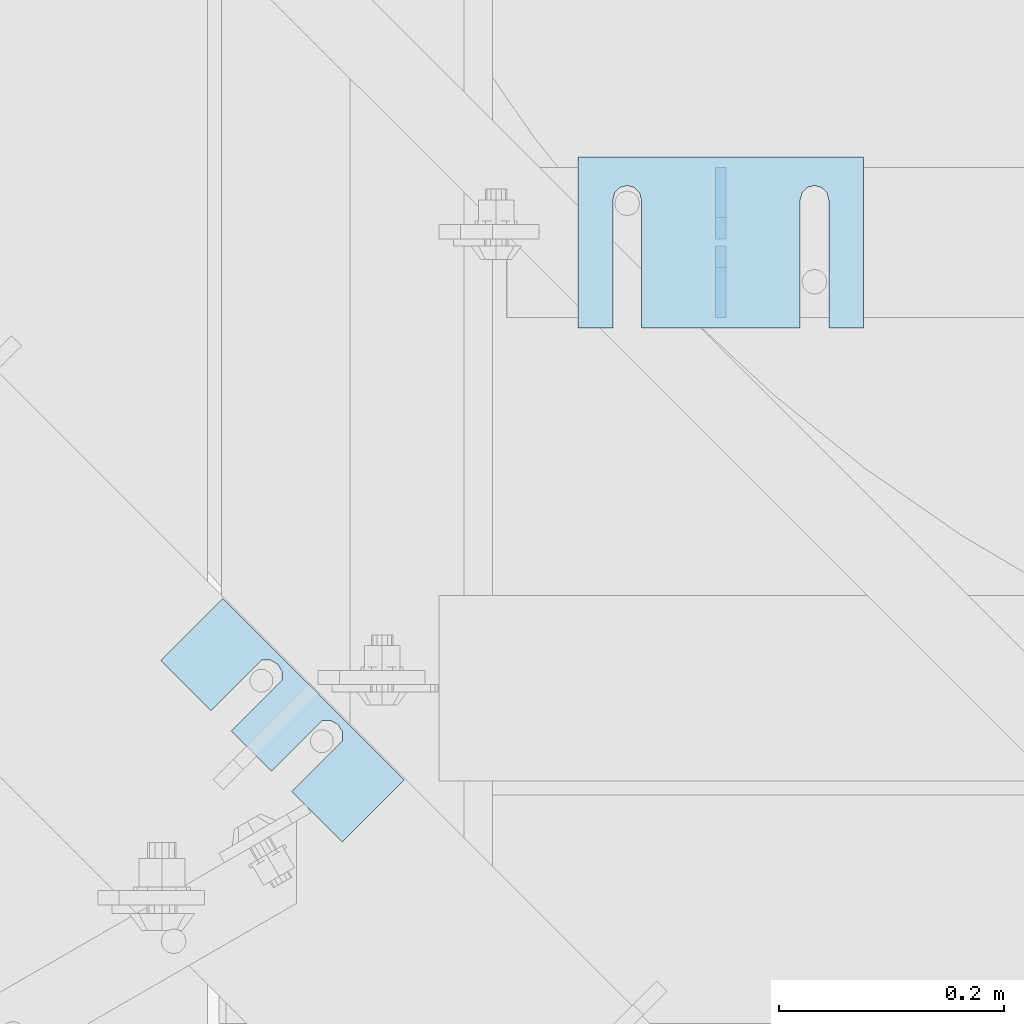
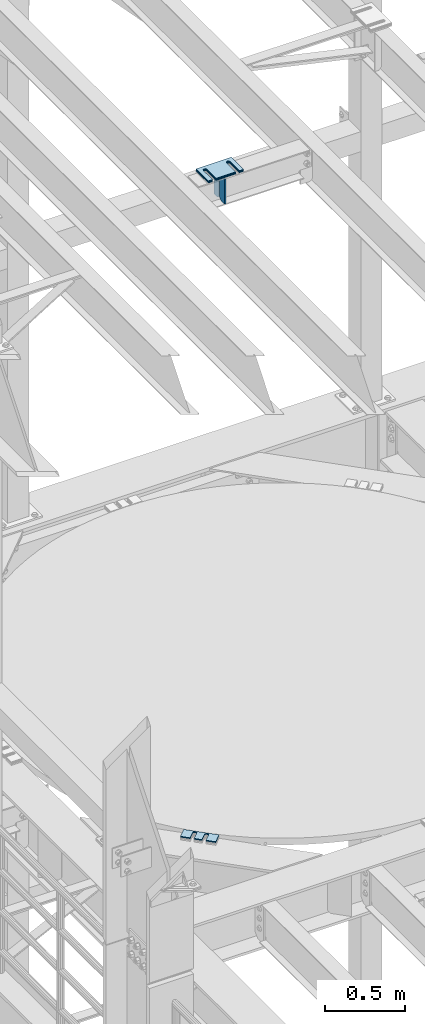
# One storey, part 1761 of 1876: 10 plates, 9 elements without a shape of their own.
"""IFC2X3 building model written with IfcOpenShell, lengths in millimetres."""

from ifc_helpers import new_model, si_unit, frame, origin_with_axes, place, context, subcontext, project, spatial, faceted_brep, material, type_object, element, aggregate, save


model = new_model("IFC2X3")

# Units and contexts
model_context = context("Model", 3, precision=1e-05, world=origin_with_axes())
body_context = subcontext(model_context, "Body", "Model", "MODEL_VIEW")
ifc_project = project(units=[si_unit("LENGTHUNIT", "METRE", prefix="MILLI"), si_unit("AREAUNIT", "SQUARE_METRE"), si_unit("VOLUMEUNIT", "CUBIC_METRE"), si_unit("MASSUNIT", "GRAM", prefix="KILO"), si_unit("TIMEUNIT", "SECOND"), si_unit("PLANEANGLEUNIT", "RADIAN"), si_unit("SOLIDANGLEUNIT", "STERADIAN"), si_unit("THERMODYNAMICTEMPERATUREUNIT", "DEGREE_CELSIUS"), si_unit("LUMINOUSINTENSITYUNIT", "LUMEN")], contexts=[model_context])

# Site, building, storey
site_placement = place(None, origin_with_axes())
site = spatial("IfcSite", under=ifc_project, at=site_placement, CompositionType="ELEMENT")
building_placement = place(site_placement, origin_with_axes())
building = spatial("IfcBuilding", under=site, at=building_placement, Name="Undefined", CompositionType="ELEMENT")
storey_placement = place(building_placement, origin_with_axes())
storey = spatial("IfcBuildingStorey", under=building, at=storey_placement, Name="Undefined", CompositionType="ELEMENT", Elevation=0.0)

# Assembly, plates
assembly_1_placement = place(storey_placement, origin_with_axes())
assembly_1 = element("IfcElementAssembly", 1, at=assembly_1_placement, inside=storey, Name="BEAM", AssemblyPlace="NOTDEFINED", PredefinedType="RIGID_FRAME")
ifc_material = material(Name="STEEL/A36")
plate_type_1 = type_object("IfcPlateType", PredefinedType="NOTDEFINED")
plate_1_placement = place(assembly_1_placement, frame((2184.41047110072, 10445.7476196289, 17784.7625), z_axis=(0.0, 0.0, 1.0), x_axis=(0.0, 1.0, 0.0)))
plate_1 = element("IfcPlate", 2, at=plate_1_placement, type_object=plate_type_1, material=ifc_material, Name="PLATE", context=body_context, shape_type="Brep", body=[
    faceted_brep([(0.0, -4.76249999999982, 0.0), (0.0, -4.76249999999982, 190.5), (0.0, 4.76249999999982, 190.5), (0.0, 4.76249999999982, 0.0), (44.4500007629395, -4.76249999999982, 190.5), (44.4500007629395, 4.76249999999982, 190.5), (63.5, -4.76249999999982, 171.450000762939), (63.5, 4.76249999999982, 171.450000762939), (63.5, -4.76249999999982, 19.0499992370605), (63.5, 4.76249999999982, 19.0499992370605), (44.4500007629395, -4.76249999999982, 0.0), (44.4500007629395, 4.76249999999982, 0.0)], [[[0, 1, 2, 3]], [[1, 4, 5, 2]], [[4, 6, 7, 5]], [[6, 8, 9, 7]], [[8, 10, 11, 9]], [[10, 0, 3, 11]], [[5, 7, 9, 11, 3, 2]], [[10, 8, 6, 4, 1, 0]]]),
])
plate_2_placement = place(assembly_1_placement, frame((2184.41047110072, 10515.5976196289, 17784.7625), z_axis=(0.0, 0.0, 1.0), x_axis=(0.0, 1.0, 0.0)))
plate_2 = element("IfcPlate", 3, at=plate_2_placement, type_object=plate_type_1, material=ifc_material, Name="PLATE", context=body_context, shape_type="Brep", body=[
    faceted_brep([(0.0, -4.76249999999982, 19.0499992370605), (0.0, -4.76249999999982, 171.450000762939), (0.0, 4.76249999999982, 171.450000762939), (0.0, 4.76249999999982, 19.0499992370605), (19.0499992370605, -4.76249999999982, 190.5), (19.0499992370605, 4.76249999999982, 190.5), (63.5, -4.76249999999982, 190.5), (63.5, 4.76249999999982, 190.5), (63.5, -4.76249999999982, 0.0), (63.5, 4.76249999999982, 0.0), (19.0499992370605, -4.76249999999982, 0.0), (19.0499992370605, 4.76249999999982, 0.0)], [[[0, 1, 2, 3]], [[1, 4, 5, 2]], [[4, 6, 7, 5]], [[6, 8, 9, 7]], [[8, 10, 11, 9]], [[10, 0, 3, 11]], [[5, 7, 9, 11, 3, 2]], [[10, 8, 6, 4, 1, 0]]]),
])
aggregate(assembly_1, [plate_1, plate_2])

# Assembly, plate
assembly_2_placement = place(storey_placement, origin_with_axes())
assembly_2 = element("IfcElementAssembly", 4, at=assembly_2_placement, inside=storey, Name="SHIM PLATE", AssemblyPlace="NOTDEFINED", PredefinedType="RIGID_FRAME")
plate_type_2 = type_object("IfcPlateType", PredefinedType="NOTDEFINED")
plate_3_placement = place(assembly_2_placement, frame((1685.49921187468, 10140.2424941069, 13335.7925), z_axis=(0.707124703959405, -0.707088857959397, 0.0), x_axis=(0.707088857959397, 0.707124703959405, 0.0)))
plate_3 = element("IfcPlate", 5, at=plate_3_placement, type_object=plate_type_2, material=ifc_material, Name="SHIM PLATE", context=body_context, shape_type="Brep", body=[
    faceted_brep([(-2.69435986410826e-07, -0.793499999999767, 88.9036802523933), (-2.69435986410826e-07, 0.793499999999767, 88.9036802523933), (64.2890073715625, 0.793499999999767, 88.9052190745724), (64.2890073715625, -0.793499999999767, 88.9052190745724), (69.5243873298787, 0.793499999999767, 83.4915584105911), (69.5243873298787, -0.793499999999767, 83.4915584105911), (64.2896161919252, -0.793499999999767, 63.5071916498637), (64.2896161919252, 0.793499999999767, 63.5071916498637), (-1.92456354852766e-07, 0.793499999999767, 63.5036806291719), (-1.92456354852766e-07, -0.793499999999767, 63.5036806291719), (69.5247366006915, -0.793499999999767, 68.9211033039346), (69.5247366006915, 0.793499999999767, 68.9211033039346), (71.4330651893342, -0.793499999999767, 76.2063766063075), (71.4330651893342, 0.793499999999767, 76.2063766063075), (64.2877911166179, -0.793499999999767, 139.707191628078), (64.2877911166179, 0.793499999999767, 139.707191628078), (-4.23393430537544e-07, 0.793499999999767, 139.703680607393), (-4.23393430537544e-07, -0.793499999999767, 139.703680607393), (69.522911525386, -0.793499999999767, 145.12110328215), (69.522911525386, 0.793499999999767, 145.12110328215), (71.4312401140269, -0.793499999999767, 152.406376584524), (71.4312401140269, 0.793499999999767, 152.406376584524), (69.5225622545713, -0.793499999999767, 159.691558388807), (69.5225622545713, 0.793499999999767, 159.691558388807), (64.287182296257, -0.793499999999767, 165.105219052788), (64.287182296257, 0.793499999999767, 165.105219052788), (-5.00373062095605e-07, -0.793499999999767, 165.103680230615), (-5.00373062095605e-07, 0.793499999999767, 165.103680230615), (-6.92811227054335e-07, -0.793499999999767, 228.601303100698), (-6.92811227054335e-07, 0.793499999999767, 228.601303100698), (78.1460113524699, -0.793499999999767, 228.601303100651), (78.1460113524699, 0.793499999999767, 228.601303100651), (78.1460113525918, -0.793499999999767, -4.91127138957381e-11), (78.1460113525918, 0.793499999999767, -4.91127138957381e-11), (9.09494701772928e-13, -0.793499999999767, 0.0), (9.09494701772928e-13, 0.793499999999767, 0.0)], [[[0, 1, 2, 3]], [[3, 2, 4, 5]], [[6, 7, 8, 9]], [[10, 11, 7, 6]], [[12, 13, 11, 10]], [[5, 4, 13, 12]], [[14, 15, 16, 17]], [[18, 19, 15, 14]], [[20, 21, 19, 18]], [[22, 23, 21, 20]], [[24, 25, 23, 22]], [[26, 27, 25, 24]], [[28, 29, 27, 26]], [[28, 30, 31, 29]], [[30, 32, 33, 31]], [[32, 34, 35, 33]], [[35, 34, 9, 8]], [[2, 1, 16, 15, 19, 21, 23, 25, 27, 29, 31, 33, 35, 8, 7, 11, 13, 4]], [[17, 16, 1, 0]], [[6, 9, 34, 32, 30, 28, 26, 24, 22, 20, 18, 14, 17, 0, 3, 5, 12, 10]]]),
])
aggregate(assembly_2, [plate_3])

assembly_3_placement = place(storey_placement, origin_with_axes())
assembly_3 = element("IfcElementAssembly", 6, at=assembly_3_placement, inside=storey, Name="SHIM PLATE", AssemblyPlace="NOTDEFINED", PredefinedType="RIGID_FRAME")
plate_type_3 = type_object("IfcPlateType", PredefinedType="NOTDEFINED")
plate_4_placement = place(assembly_3_placement, frame((1685.49921187468, 10140.2424941069, 13333.4115), z_axis=(0.707124703959405, -0.707088857959397, 0.0), x_axis=(0.707088857959397, 0.707124703959405, 0.0)))
plate_4 = element("IfcPlate", 7, at=plate_4_placement, type_object=plate_type_3, material=ifc_material, Name="SHIM PLATE", context=body_context, shape_type="Brep", body=[
    faceted_brep([(-2.69435986410826e-07, -1.58749999999964, 88.9036802523951), (-2.69435986410826e-07, 1.58749999999964, 88.9036802523951), (64.2890073715644, 1.58749999999964, 88.9052190745733), (64.2890073715644, -1.58749999999964, 88.9052190745733), (69.5243873298787, 1.58749999999964, 83.491558410592), (69.5243873298787, -1.58749999999964, 83.491558410592), (64.2896161919234, -1.58749999999964, 63.5071916498646), (64.2896161919234, 1.58749999999964, 63.5071916498646), (-1.92456354852766e-07, 1.58749999999964, 63.5036806291737), (-1.92456354852766e-07, -1.58749999999964, 63.5036806291737), (69.5247366006934, -1.58749999999964, 68.9211033039355), (69.5247366006934, 1.58749999999964, 68.9211033039355), (71.4330651893342, -1.58749999999964, 76.2063766063084), (71.4330651893342, 1.58749999999964, 76.2063766063084), (64.2877911166179, -1.58749999999964, 139.707191628079), (64.2877911166179, 1.58749999999964, 139.707191628079), (-4.23391611548141e-07, 1.58749999999964, 139.703680607395), (-4.23391611548141e-07, -1.58749999999964, 139.703680607395), (69.522911525386, -1.58749999999964, 145.121103282152), (69.522911525386, 1.58749999999964, 145.121103282152), (71.4312401140269, -1.58749999999964, 152.406376584525), (71.4312401140269, 1.58749999999964, 152.406376584525), (69.5225622545713, -1.58749999999964, 159.691558388808), (69.5225622545713, 1.58749999999964, 159.691558388808), (64.2871822962588, -1.58749999999964, 165.105219052789), (64.2871822962588, 1.58749999999964, 165.105219052789), (-5.00371243106201e-07, -1.58749999999964, 165.103680230615), (-5.00371243106201e-07, 1.58749999999964, 165.103680230615), (-6.92813046043739e-07, -1.58749999999964, 228.601303100699), (-6.92813046043739e-07, 1.58749999999964, 228.601303100699), (78.1460113524699, -1.58749999999964, 228.601303100651), (78.1460113524699, 1.58749999999964, 228.601303100651), (78.1460113525918, -1.58749999999964, -4.72937244921923e-11), (78.1460113525918, 1.58749999999964, -4.72937244921923e-11), (9.09494701772928e-13, -1.58750000000146, 4.54747350886464e-13), (9.09494701772928e-13, 1.58750000000146, 4.54747350886464e-13)], [[[0, 1, 2, 3]], [[3, 2, 4, 5]], [[6, 7, 8, 9]], [[10, 11, 7, 6]], [[12, 13, 11, 10]], [[5, 4, 13, 12]], [[14, 15, 16, 17]], [[18, 19, 15, 14]], [[20, 21, 19, 18]], [[22, 23, 21, 20]], [[24, 25, 23, 22]], [[26, 27, 25, 24]], [[28, 29, 27, 26]], [[28, 30, 31, 29]], [[30, 32, 33, 31]], [[32, 34, 35, 33]], [[35, 34, 9, 8]], [[2, 1, 16, 15, 19, 21, 23, 25, 27, 29, 31, 33, 35, 8, 7, 11, 13, 4]], [[17, 16, 1, 0]], [[6, 9, 34, 32, 30, 28, 26, 24, 22, 20, 18, 14, 17, 0, 3, 5, 12, 10]]]),
])
aggregate(assembly_3, [plate_4])

assembly_4_placement = place(storey_placement, origin_with_axes())
assembly_4 = element("IfcElementAssembly", 8, at=assembly_4_placement, inside=storey, Name="SHIM PLATE", AssemblyPlace="NOTDEFINED", PredefinedType="RIGID_FRAME")
plate_5_placement = place(assembly_4_placement, frame((1685.49921187468, 10140.2424941069, 13330.2365), z_axis=(0.707124703959405, -0.707088857959397, 0.0), x_axis=(0.707088857959397, 0.707124703959405, 0.0)))
plate_5 = element("IfcPlate", 9, at=plate_5_placement, type_object=plate_type_3, material=ifc_material, Name="SHIM PLATE", context=body_context, shape_type="Brep", body=[
    faceted_brep([(-2.69435986410826e-07, -1.58749999999964, 88.9036802523951), (-2.69435986410826e-07, 1.58749999999964, 88.9036802523951), (64.2890073715644, 1.58749999999964, 88.9052190745733), (64.2890073715644, -1.58749999999964, 88.9052190745733), (69.5243873298787, 1.58749999999964, 83.491558410592), (69.5243873298787, -1.58749999999964, 83.491558410592), (64.2896161919234, -1.58749999999964, 63.5071916498646), (64.2896161919234, 1.58749999999964, 63.5071916498646), (-1.92456354852766e-07, 1.58749999999964, 63.5036806291737), (-1.92456354852766e-07, -1.58749999999964, 63.5036806291737), (69.5247366006934, -1.58749999999964, 68.9211033039355), (69.5247366006934, 1.58749999999964, 68.9211033039355), (71.4330651893342, -1.58749999999964, 76.2063766063084), (71.4330651893342, 1.58749999999964, 76.2063766063084), (64.2877911166179, -1.58749999999964, 139.707191628079), (64.2877911166179, 1.58749999999964, 139.707191628079), (-4.23391611548141e-07, 1.58749999999964, 139.703680607395), (-4.23391611548141e-07, -1.58749999999964, 139.703680607395), (69.522911525386, -1.58749999999964, 145.121103282152), (69.522911525386, 1.58749999999964, 145.121103282152), (71.4312401140269, -1.58749999999964, 152.406376584525), (71.4312401140269, 1.58749999999964, 152.406376584525), (69.5225622545713, -1.58749999999964, 159.691558388808), (69.5225622545713, 1.58749999999964, 159.691558388808), (64.2871822962588, -1.58749999999964, 165.105219052789), (64.2871822962588, 1.58749999999964, 165.105219052789), (-5.00371243106201e-07, -1.58749999999964, 165.103680230615), (-5.00371243106201e-07, 1.58749999999964, 165.103680230615), (-6.92813046043739e-07, -1.58749999999964, 228.601303100699), (-6.92813046043739e-07, 1.58749999999964, 228.601303100699), (78.1460113524699, -1.58749999999964, 228.601303100651), (78.1460113524699, 1.58749999999964, 228.601303100651), (78.1460113525918, -1.58749999999964, -4.72937244921923e-11), (78.1460113525918, 1.58749999999964, -4.72937244921923e-11), (9.09494701772928e-13, -1.58750000000146, 4.54747350886464e-13), (9.09494701772928e-13, 1.58750000000146, 4.54747350886464e-13)], [[[0, 1, 2, 3]], [[3, 2, 4, 5]], [[6, 7, 8, 9]], [[10, 11, 7, 6]], [[12, 13, 11, 10]], [[5, 4, 13, 12]], [[14, 15, 16, 17]], [[18, 19, 15, 14]], [[20, 21, 19, 18]], [[22, 23, 21, 20]], [[24, 25, 23, 22]], [[26, 27, 25, 24]], [[28, 29, 27, 26]], [[28, 30, 31, 29]], [[30, 32, 33, 31]], [[32, 34, 35, 33]], [[35, 34, 9, 8]], [[2, 1, 16, 15, 19, 21, 23, 25, 27, 29, 31, 33, 35, 8, 7, 11, 13, 4]], [[17, 16, 1, 0]], [[6, 9, 34, 32, 30, 28, 26, 24, 22, 20, 18, 14, 17, 0, 3, 5, 12, 10]]]),
])
aggregate(assembly_4, [plate_5])

assembly_5_placement = place(storey_placement, origin_with_axes())
assembly_5 = element("IfcElementAssembly", 10, at=assembly_5_placement, inside=storey, Name="SHIM PLATE", AssemblyPlace="NOTDEFINED", PredefinedType="RIGID_FRAME")
plate_type_4 = type_object("IfcPlateType", PredefinedType="NOTDEFINED")
plate_6_placement = place(assembly_5_placement, frame((2311.41072536354, 10588.6220636382, 18009.3925), z_axis=(0.0, -1.0, 0.0), x_axis=(-1.0, 0.0, 0.0)))
plate_6 = element("IfcPlate", 11, at=plate_6_placement, type_object=plate_type_4, material=ifc_material, Name="SHIM PLATE", context=body_context, shape_type="Brep", body=[
    faceted_brep([(30.8791924037423, -0.793499999999767, 152.398895263674), (30.8814140421409, -0.793499999999767, 38.0994505407325), (30.8814140421409, 0.793499999999767, 38.0994505407325), (30.8791924037423, 0.793499999999767, 152.398895263674), (32.5828868936751, -0.793499999999767, 31.7494480341243), (32.5828868936751, 0.793499999999767, 31.7494480341243), (37.2314075583954, -0.793499999999767, 27.1009216732054), (37.2314075583954, 0.793499999999767, 27.1009216732054), (43.5814079800521, -0.793499999999767, 25.3994410405157), (43.5814079800521, 0.793499999999767, 25.3994410405157), (49.9314097200559, -0.793499999999767, 27.1009167530574), (49.9314097200559, 0.793499999999767, 27.1009167530574), (54.5799339865616, -0.793499999999767, 31.7494395121785), (54.5799339865616, 0.793499999999767, 31.7494395121785), (56.2814117582284, -0.793499999999767, 38.0994407004391), (56.2814117582284, 0.793499999999767, 38.0994407004391), (56.2791901197206, -0.793499999999767, 152.398894414155), (56.2791901197206, 0.793499999999767, 152.398895263676), (9.09494701772928e-13, -0.793499999999767, 0.0), (1.98268335225293e-05, -0.793499999999767, 152.398895263672), (1.98268335225293e-05, 0.793499999999767, 152.398895263672), (9.09494701772928e-13, 0.793499999999767, 0.0), (253.999542236328, -0.793499999999767, 6.16182660451159e-11), (253.999542236328, 0.793499999999767, 6.16182660451159e-11), (253.999557495107, -0.793499999999767, 152.398895263688), (253.999557495107, 0.793499999999767, 152.398895263688), (223.116882380463, 0.793499999999767, 152.398895263686), (223.116882380463, -0.793499999999767, 152.398895415181), (223.119104018971, 0.793499999999767, 38.0994417014649), (223.119104018971, -0.793499999999767, 38.0994417014649), (221.417626247304, 0.793499999999767, 31.7494405132047), (221.417626247304, -0.793499999999767, 31.7494405132047), (216.769101980798, 0.793499999999767, 27.1009177540836), (216.769101980798, -0.793499999999767, 27.1009177540836), (210.419100240794, 0.793499999999767, 25.399442041542), (210.419100240794, -0.793499999999767, 25.399442041542), (204.069099819138, 0.793499999999767, 27.1009226742317), (204.069099819138, -0.793499999999767, 27.1009226742317), (199.420579154417, 0.793499999999767, 31.7494490351505), (199.420579154417, -0.793499999999767, 31.7494490351505), (197.719106302883, 0.793499999999767, 38.0994515417583), (197.719106302883, -0.793499999999767, 38.0994515417583), (197.716884664484, -0.793499999999767, 152.398895263684), (197.716884664484, 0.793499999999767, 152.398895263684)], [[[0, 1, 2, 3]], [[4, 5, 2, 1]], [[6, 7, 5, 4]], [[8, 9, 7, 6]], [[10, 11, 9, 8]], [[12, 13, 11, 10]], [[14, 15, 13, 12]], [[16, 17, 15, 14]], [[18, 19, 20, 21]], [[22, 18, 21, 23]], [[24, 22, 23, 25]], [[24, 25, 26, 27]], [[27, 26, 28, 29]], [[29, 28, 30, 31]], [[31, 30, 32, 33]], [[33, 32, 34, 35]], [[35, 34, 36, 37]], [[37, 36, 38, 39]], [[39, 38, 40, 41]], [[42, 41, 40, 43]], [[12, 10, 8, 6, 4, 1, 0, 19, 18, 22, 24, 27, 29, 31, 33, 35, 37, 39, 41, 42, 16, 14]], [[20, 19, 0, 3]], [[43, 40, 38, 36, 34, 32, 30, 28, 26, 25, 23, 21, 20, 3, 2, 5, 7, 9, 11, 13, 15, 17]], [[42, 43, 17, 16]]]),
])
aggregate(assembly_5, [plate_6])

assembly_6_placement = place(storey_placement, origin_with_axes())
assembly_6 = element("IfcElementAssembly", 12, at=assembly_6_placement, inside=storey, Name="SHIM PLATE", AssemblyPlace="NOTDEFINED", PredefinedType="RIGID_FRAME")
plate_type_5 = type_object("IfcPlateType", PredefinedType="NOTDEFINED")
plate_7_placement = place(assembly_6_placement, frame((2311.41072536354, 10588.6220636384, 18007.0115), z_axis=(0.0, -1.0, 0.0), x_axis=(-1.0, 0.0, 0.0)))
plate_7 = element("IfcPlate", 13, at=plate_7_placement, type_object=plate_type_5, material=ifc_material, Name="SHIM PLATE", context=body_context, shape_type="Brep", body=[
    faceted_brep([(30.8791924037423, -1.58750000000146, 152.398895263674), (30.8814140421409, -1.58750000000146, 38.0994505407325), (30.8814140421409, 1.58750000000146, 38.0994505407325), (30.8791924037423, 1.58750000000146, 152.398895263674), (32.5828868936751, -1.58750000000146, 31.7494480341243), (32.5828868936751, 1.58750000000146, 31.7494480341243), (37.2314075583954, -1.58750000000146, 27.1009216732054), (37.2314075583954, 1.58750000000146, 27.1009216732054), (43.5814079800521, -1.58750000000146, 25.3994410405157), (43.5814079800521, 1.58750000000146, 25.3994410405157), (49.9314097200559, -1.58750000000146, 27.1009167530574), (49.9314097200559, 1.58750000000146, 27.1009167530574), (54.5799339865616, -1.58750000000146, 31.7494395121785), (54.5799339865616, 1.58750000000146, 31.7494395121785), (56.2814117582284, -1.58750000000146, 38.0994407004391), (56.2814117582284, 1.58750000000146, 38.0994407004391), (56.2791901197206, -1.58750000000146, 152.398894414155), (56.2791901197206, 1.58750000000146, 152.398895263676), (9.09494701772928e-13, -1.58750000000146, 4.54747350886464e-13), (1.98264133359771e-05, -1.58750000000146, 152.398895263672), (1.98264133359771e-05, 1.58750000000146, 152.398895263672), (9.09494701772928e-13, 1.58750000000146, 4.54747350886464e-13), (253.999542236328, -1.58750000000146, 6.16182660451159e-11), (253.999542236328, 1.58750000000146, 6.16182660451159e-11), (253.999557495107, -1.58750000000146, 152.398895263688), (253.999557495107, 1.58750000000146, 152.398895263688), (223.116882380463, 1.58750000000146, 152.398895263686), (223.116882380463, -1.58750000000146, 152.398895415181), (223.119104018971, 1.58750000000146, 38.0994417014649), (223.119104018971, -1.58750000000146, 38.0994417014649), (221.417626247304, 1.58750000000146, 31.7494405132047), (221.417626247304, -1.58750000000146, 31.7494405132047), (216.769101980798, 1.58750000000146, 27.1009177540836), (216.769101980798, -1.58750000000146, 27.1009177540836), (210.419100240794, 1.58750000000146, 25.399442041542), (210.419100240794, -1.58750000000146, 25.399442041542), (204.069099819138, 1.58750000000146, 27.1009226742317), (204.069099819138, -1.58750000000146, 27.1009226742317), (199.420579154417, 1.58750000000146, 31.7494490351505), (199.420579154417, -1.58750000000146, 31.7494490351505), (197.719106302883, 1.58750000000146, 38.0994515417583), (197.719106302883, -1.58750000000146, 38.0994515417583), (197.716884664484, -1.58750000000146, 152.398895263684), (197.716884664484, 1.58750000000146, 152.398895263684)], [[[0, 1, 2, 3]], [[4, 5, 2, 1]], [[6, 7, 5, 4]], [[8, 9, 7, 6]], [[10, 11, 9, 8]], [[12, 13, 11, 10]], [[14, 15, 13, 12]], [[16, 17, 15, 14]], [[18, 19, 20, 21]], [[22, 18, 21, 23]], [[24, 22, 23, 25]], [[24, 25, 26, 27]], [[27, 26, 28, 29]], [[29, 28, 30, 31]], [[31, 30, 32, 33]], [[33, 32, 34, 35]], [[35, 34, 36, 37]], [[37, 36, 38, 39]], [[39, 38, 40, 41]], [[42, 41, 40, 43]], [[12, 10, 8, 6, 4, 1, 0, 19, 18, 22, 24, 27, 29, 31, 33, 35, 37, 39, 41, 42, 16, 14]], [[20, 19, 0, 3]], [[43, 40, 38, 36, 34, 32, 30, 28, 26, 25, 23, 21, 20, 3, 2, 5, 7, 9, 11, 13, 15, 17]], [[42, 43, 17, 16]]]),
])
aggregate(assembly_6, [plate_7])

assembly_7_placement = place(storey_placement, origin_with_axes())
assembly_7 = element("IfcElementAssembly", 14, at=assembly_7_placement, inside=storey, Name="SHIM PLATE", AssemblyPlace="NOTDEFINED", PredefinedType="RIGID_FRAME")
plate_8_placement = place(assembly_7_placement, frame((2311.41072536354, 10588.6220636387, 18003.8365), z_axis=(0.0, -1.0, 0.0), x_axis=(-1.0, 0.0, 0.0)))
plate_8 = element("IfcPlate", 15, at=plate_8_placement, type_object=plate_type_5, material=ifc_material, Name="SHIM PLATE", context=body_context, shape_type="Brep", body=[
    faceted_brep([(30.8791924037423, -1.58750000000146, 152.398895263674), (30.8814140421409, -1.58750000000146, 38.0994505407325), (30.8814140421409, 1.58750000000146, 38.0994505407325), (30.8791924037423, 1.58750000000146, 152.398895263674), (32.5828868936751, -1.58750000000146, 31.7494480341243), (32.5828868936751, 1.58750000000146, 31.7494480341243), (37.2314075583954, -1.58750000000146, 27.1009216732054), (37.2314075583954, 1.58750000000146, 27.1009216732054), (43.5814079800521, -1.58750000000146, 25.3994410405157), (43.5814079800521, 1.58750000000146, 25.3994410405157), (49.9314097200559, -1.58750000000146, 27.1009167530574), (49.9314097200559, 1.58750000000146, 27.1009167530574), (54.5799339865616, -1.58750000000146, 31.7494395121785), (54.5799339865616, 1.58750000000146, 31.7494395121785), (56.2814117582284, -1.58750000000146, 38.0994407004391), (56.2814117582284, 1.58750000000146, 38.0994407004391), (56.2791901197206, -1.58750000000146, 152.398894414155), (56.2791901197206, 1.58750000000146, 152.398895263676), (9.09494701772928e-13, -1.58750000000146, 4.54747350886464e-13), (1.98264133359771e-05, -1.58750000000146, 152.398895263672), (1.98264133359771e-05, 1.58750000000146, 152.398895263672), (9.09494701772928e-13, 1.58750000000146, 4.54747350886464e-13), (253.999542236328, -1.58750000000146, 6.16182660451159e-11), (253.999542236328, 1.58750000000146, 6.16182660451159e-11), (253.999557495107, -1.58750000000146, 152.398895263688), (253.999557495107, 1.58750000000146, 152.398895263688), (223.116882380463, 1.58750000000146, 152.398895263686), (223.116882380463, -1.58750000000146, 152.398895415181), (223.119104018971, 1.58750000000146, 38.0994417014649), (223.119104018971, -1.58750000000146, 38.0994417014649), (221.417626247304, 1.58750000000146, 31.7494405132047), (221.417626247304, -1.58750000000146, 31.7494405132047), (216.769101980798, 1.58750000000146, 27.1009177540836), (216.769101980798, -1.58750000000146, 27.1009177540836), (210.419100240794, 1.58750000000146, 25.399442041542), (210.419100240794, -1.58750000000146, 25.399442041542), (204.069099819138, 1.58750000000146, 27.1009226742317), (204.069099819138, -1.58750000000146, 27.1009226742317), (199.420579154417, 1.58750000000146, 31.7494490351505), (199.420579154417, -1.58750000000146, 31.7494490351505), (197.719106302883, 1.58750000000146, 38.0994515417583), (197.719106302883, -1.58750000000146, 38.0994515417583), (197.716884664484, -1.58750000000146, 152.398895263684), (197.716884664484, 1.58750000000146, 152.398895263684)], [[[0, 1, 2, 3]], [[4, 5, 2, 1]], [[6, 7, 5, 4]], [[8, 9, 7, 6]], [[10, 11, 9, 8]], [[12, 13, 11, 10]], [[14, 15, 13, 12]], [[16, 17, 15, 14]], [[18, 19, 20, 21]], [[22, 18, 21, 23]], [[24, 22, 23, 25]], [[24, 25, 26, 27]], [[27, 26, 28, 29]], [[29, 28, 30, 31]], [[31, 30, 32, 33]], [[33, 32, 34, 35]], [[35, 34, 36, 37]], [[37, 36, 38, 39]], [[39, 38, 40, 41]], [[42, 41, 40, 43]], [[12, 10, 8, 6, 4, 1, 0, 19, 18, 22, 24, 27, 29, 31, 33, 35, 37, 39, 41, 42, 16, 14]], [[20, 19, 0, 3]], [[43, 40, 38, 36, 34, 32, 30, 28, 26, 25, 23, 21, 20, 3, 2, 5, 7, 9, 11, 13, 15, 17]], [[42, 43, 17, 16]]]),
])
aggregate(assembly_7, [plate_8])

assembly_8_placement = place(storey_placement, origin_with_axes())
assembly_8 = element("IfcElementAssembly", 16, at=assembly_8_placement, inside=storey, Name="SHIM PLATE", AssemblyPlace="NOTDEFINED", PredefinedType="RIGID_FRAME")
plate_type_6 = type_object("IfcPlateType", PredefinedType="NOTDEFINED")
plate_9_placement = place(assembly_8_placement, frame((2311.41072536354, 10588.6220636389, 17999.868), z_axis=(0.0, -1.0, 0.0), x_axis=(-1.0, 0.0, 0.0)))
plate_9 = element("IfcPlate", 17, at=plate_9_placement, type_object=plate_type_6, material=ifc_material, Name="SHIM PLATE", context=body_context, shape_type="Brep", body=[
    faceted_brep([(30.8791924037423, -2.38100000000122, 152.398895263674), (30.8814140421409, -2.38100000000122, 38.0994505407325), (30.8814140421409, 2.38100000000122, 38.0994505407325), (30.8791924037423, 2.38100000000122, 152.398895263674), (32.5828868936751, -2.38100000000122, 31.7494480341243), (32.5828868936751, 2.38100000000122, 31.7494480341243), (37.2314075583954, -2.38100000000122, 27.1009216732054), (37.2314075583954, 2.38100000000122, 27.1009216732054), (43.5814079800521, -2.38100000000122, 25.3994410405157), (43.5814079800521, 2.38100000000122, 25.3994410405157), (49.9314097200559, -2.38100000000122, 27.1009167530574), (49.9314097200559, 2.38100000000122, 27.1009167530574), (54.5799339865616, -2.38100000000122, 31.7494395121785), (54.5799339865616, 2.38100000000122, 31.7494395121785), (56.2814117582284, -2.38100000000122, 38.0994407004391), (56.2814117582284, 2.38100000000122, 38.0994407004391), (56.2791901197206, -2.38100000000122, 152.398894414155), (56.2791901197206, 2.38100000000122, 152.398895263676), (0.0, -2.38100000000122, 4.54747350886464e-13), (1.98259931494249e-05, -2.38100000000122, 152.398895263672), (1.98259931494249e-05, 2.38100000000122, 152.398895263672), (0.0, 2.38100000000122, 4.54747350886464e-13), (253.999542236328, -2.38100000000122, 6.16182660451159e-11), (253.999542236328, 2.38100000000122, 6.16182660451159e-11), (253.999557495107, -2.38100000000122, 152.398895263688), (253.999557495107, 2.38100000000122, 152.398895263688), (223.116882380463, 2.38100000000122, 152.398895263686), (223.116882380463, -2.38100000000122, 152.398895415181), (223.119104018971, 2.38100000000122, 38.0994417014649), (223.119104018971, -2.38100000000122, 38.0994417014649), (221.417626247304, 2.38100000000122, 31.7494405132047), (221.417626247304, -2.38100000000122, 31.7494405132047), (216.769101980798, 2.38100000000122, 27.1009177540836), (216.769101980798, -2.38100000000122, 27.1009177540836), (210.419100240794, 2.38100000000122, 25.399442041542), (210.419100240794, -2.38100000000122, 25.399442041542), (204.069099819138, 2.38100000000122, 27.1009226742317), (204.069099819138, -2.38100000000122, 27.1009226742317), (199.420579154417, 2.38100000000122, 31.7494490351505), (199.420579154417, -2.38100000000122, 31.7494490351505), (197.719106302883, 2.38100000000122, 38.0994515417583), (197.719106302883, -2.38100000000122, 38.0994515417583), (197.716884664484, -2.38100000000122, 152.398895263684), (197.716884664484, 2.38100000000122, 152.398895263684)], [[[0, 1, 2, 3]], [[4, 5, 2, 1]], [[6, 7, 5, 4]], [[8, 9, 7, 6]], [[10, 11, 9, 8]], [[12, 13, 11, 10]], [[14, 15, 13, 12]], [[16, 17, 15, 14]], [[18, 19, 20, 21]], [[22, 18, 21, 23]], [[24, 22, 23, 25]], [[24, 25, 26, 27]], [[27, 26, 28, 29]], [[29, 28, 30, 31]], [[31, 30, 32, 33]], [[33, 32, 34, 35]], [[35, 34, 36, 37]], [[37, 36, 38, 39]], [[39, 38, 40, 41]], [[42, 41, 40, 43]], [[12, 10, 8, 6, 4, 1, 0, 19, 18, 22, 24, 27, 29, 31, 33, 35, 37, 39, 41, 42, 16, 14]], [[20, 19, 0, 3]], [[43, 40, 38, 36, 34, 32, 30, 28, 26, 25, 23, 21, 20, 3, 2, 5, 7, 9, 11, 13, 15, 17]], [[42, 43, 17, 16]]]),
])
aggregate(assembly_8, [plate_9])

assembly_9_placement = place(storey_placement, origin_with_axes())
assembly_9 = element("IfcElementAssembly", 18, at=assembly_9_placement, inside=storey, Name="SHIM PLATE", AssemblyPlace="NOTDEFINED", PredefinedType="RIGID_FRAME")
plate_10_placement = place(assembly_9_placement, frame((2311.41072536354, 10588.6220636391, 17995.106), z_axis=(0.0, -1.0, 0.0), x_axis=(-1.0, 0.0, 0.0)))
plate_10 = element("IfcPlate", 19, at=plate_10_placement, type_object=plate_type_6, material=ifc_material, Name="SHIM PLATE", context=body_context, shape_type="Brep", body=[
    faceted_brep([(30.8791924037423, -2.38100000000122, 152.398895263674), (30.8814140421409, -2.38100000000122, 38.0994505407325), (30.8814140421409, 2.38100000000122, 38.0994505407325), (30.8791924037423, 2.38100000000122, 152.398895263674), (32.5828868936751, -2.38100000000122, 31.7494480341243), (32.5828868936751, 2.38100000000122, 31.7494480341243), (37.2314075583954, -2.38100000000122, 27.1009216732054), (37.2314075583954, 2.38100000000122, 27.1009216732054), (43.5814079800521, -2.38100000000122, 25.3994410405157), (43.5814079800521, 2.38100000000122, 25.3994410405157), (49.9314097200559, -2.38100000000122, 27.1009167530574), (49.9314097200559, 2.38100000000122, 27.1009167530574), (54.5799339865616, -2.38100000000122, 31.7494395121785), (54.5799339865616, 2.38100000000122, 31.7494395121785), (56.2814117582284, -2.38100000000122, 38.0994407004391), (56.2814117582284, 2.38100000000122, 38.0994407004391), (56.2791901197206, -2.38100000000122, 152.398894414155), (56.2791901197206, 2.38100000000122, 152.398895263676), (0.0, -2.38100000000122, 4.54747350886464e-13), (1.98259931494249e-05, -2.38100000000122, 152.398895263672), (1.98259931494249e-05, 2.38100000000122, 152.398895263672), (0.0, 2.38100000000122, 4.54747350886464e-13), (253.999542236328, -2.38100000000122, 6.16182660451159e-11), (253.999542236328, 2.38100000000122, 6.16182660451159e-11), (253.999557495107, -2.38100000000122, 152.398895263688), (253.999557495107, 2.38100000000122, 152.398895263688), (223.116882380463, 2.38100000000122, 152.398895263686), (223.116882380463, -2.38100000000122, 152.398895415181), (223.119104018971, 2.38100000000122, 38.0994417014649), (223.119104018971, -2.38100000000122, 38.0994417014649), (221.417626247304, 2.38100000000122, 31.7494405132047), (221.417626247304, -2.38100000000122, 31.7494405132047), (216.769101980798, 2.38100000000122, 27.1009177540836), (216.769101980798, -2.38100000000122, 27.1009177540836), (210.419100240794, 2.38100000000122, 25.399442041542), (210.419100240794, -2.38100000000122, 25.399442041542), (204.069099819138, 2.38100000000122, 27.1009226742317), (204.069099819138, -2.38100000000122, 27.1009226742317), (199.420579154417, 2.38100000000122, 31.7494490351505), (199.420579154417, -2.38100000000122, 31.7494490351505), (197.719106302883, 2.38100000000122, 38.0994515417583), (197.719106302883, -2.38100000000122, 38.0994515417583), (197.716884664484, -2.38100000000122, 152.398895263684), (197.716884664484, 2.38100000000122, 152.398895263684)], [[[0, 1, 2, 3]], [[4, 5, 2, 1]], [[6, 7, 5, 4]], [[8, 9, 7, 6]], [[10, 11, 9, 8]], [[12, 13, 11, 10]], [[14, 15, 13, 12]], [[16, 17, 15, 14]], [[18, 19, 20, 21]], [[22, 18, 21, 23]], [[24, 22, 23, 25]], [[24, 25, 26, 27]], [[27, 26, 28, 29]], [[29, 28, 30, 31]], [[31, 30, 32, 33]], [[33, 32, 34, 35]], [[35, 34, 36, 37]], [[37, 36, 38, 39]], [[39, 38, 40, 41]], [[42, 41, 40, 43]], [[12, 10, 8, 6, 4, 1, 0, 19, 18, 22, 24, 27, 29, 31, 33, 35, 37, 39, 41, 42, 16, 14]], [[20, 19, 0, 3]], [[43, 40, 38, 36, 34, 32, 30, 28, 26, 25, 23, 21, 20, 3, 2, 5, 7, 9, 11, 13, 15, 17]], [[42, 43, 17, 16]]]),
])
aggregate(assembly_9, [plate_10])

save(model, "model.ifc")
